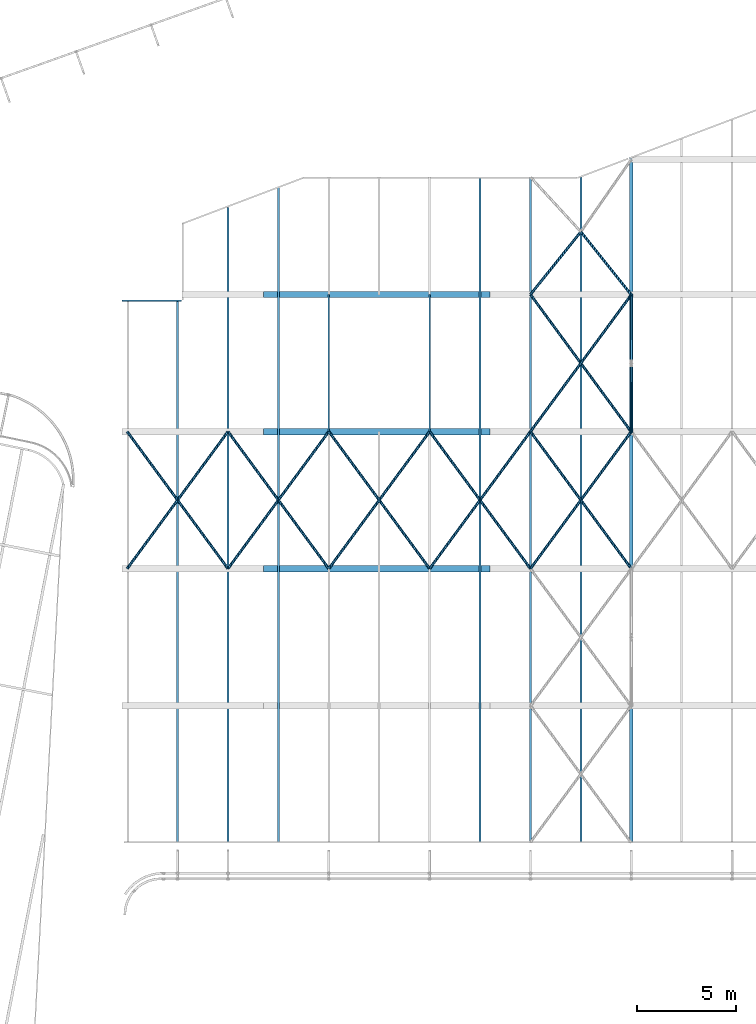
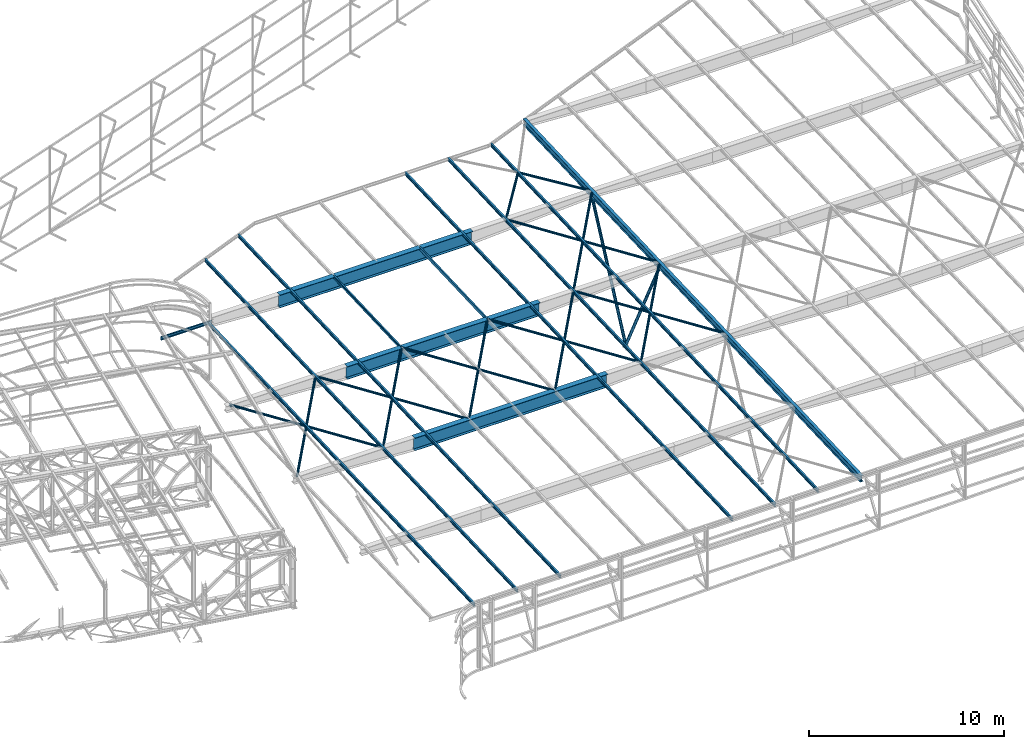
# One storey, part 114 of 215: 27 beams, 2 members, 29 elements without a shape of their own.
"""IFC2X3 building model written with IfcOpenShell, lengths in millimetres."""

from ifc_helpers import new_model, si_unit, frame, origin_with_axes, origin_2d_with_axis, place, context, subcontext, project, spatial, hollow_circle, i_section, u_section, extrude, clip, halfspace, material, type_object, element, aggregate, save


model = new_model("IFC2X3")

# Units and contexts
model_context = context("Model", 3, precision=1e-05, world=origin_with_axes())
body_context = subcontext(model_context, "Body", "Model", "MODEL_VIEW")
ifc_project = project(units=[si_unit("LENGTHUNIT", "METRE", prefix="MILLI"), si_unit("AREAUNIT", "SQUARE_METRE"), si_unit("VOLUMEUNIT", "CUBIC_METRE"), si_unit("MASSUNIT", "GRAM", prefix="KILO"), si_unit("TIMEUNIT", "SECOND"), si_unit("PLANEANGLEUNIT", "RADIAN"), si_unit("SOLIDANGLEUNIT", "STERADIAN"), si_unit("THERMODYNAMICTEMPERATUREUNIT", "DEGREE_CELSIUS"), si_unit("LUMINOUSINTENSITYUNIT", "LUMEN")], contexts=[model_context])

# Site, building, storey
site_placement = place(None, origin_with_axes())
site = spatial("IfcSite", under=ifc_project, at=site_placement, CompositionType="ELEMENT")
building_placement = place(site_placement, origin_with_axes())
building = spatial("IfcBuilding", under=site, at=building_placement, Name="Undefined", CompositionType="ELEMENT")
storey_placement = place(building_placement, origin_with_axes())
storey = spatial("IfcBuildingStorey", under=building, at=storey_placement, Name="Undefined", CompositionType="ELEMENT", Elevation=0.0)

# Assembly, beam
assembly_1_placement = place(storey_placement, origin_with_axes())
assembly_1 = element("IfcElementAssembly", 1, at=assembly_1_placement, inside=storey, Name="Steel Assembly", AssemblyPlace="NOTDEFINED", PredefinedType="RIGID_FRAME")
ifc_material_1 = material(Name="STEEL/S275JR")
beam_type_1 = type_object("IfcBeamType", Name="UPE200", PredefinedType="NOTDEFINED")
beam_1_placement = place(assembly_1_placement, frame((103874.07781238, 62264.9270571138, 3922.84069857706), z_axis=(0.0, 0.0, 1.0), x_axis=(1.0, 0.0, 0.0)))
beam_1 = element("IfcBeam", 2, at=beam_1_placement, type_object=beam_type_1, material=ifc_material_1, ObjectType="UPE200", context=body_context, shape_type="SweptSolid", body=[
    extrude(u_section(Depth=200.0, FlangeWidth=80.0, WebThickness=6.0, FlangeThickness=11.0, FilletRadius=13.0, at=origin_2d_with_axis()), frame((2999.96948241417, 7.27595761418343e-12, -1.5881706202264e-19), z_axis=(-1.0, 0.0, 0.0), x_axis=(-6.93889390390723e-18, -1.0, -3.46944695195361e-18)), (0.0, 0.0, 1.0), 3000.0),
])
aggregate(assembly_1, [beam_1])

assembly_2_placement = place(storey_placement, origin_with_axes())
assembly_2 = element("IfcElementAssembly", 3, at=assembly_2_placement, inside=storey, Name="Steel Assembly", AssemblyPlace="NOTDEFINED", PredefinedType="RIGID_FRAME")
beam_2_placement = place(assembly_2_placement, frame((114285.009686581, 55679.2143666818, 3657.96601082623), z_axis=(0.0, 0.0399624260079826, -0.999201183199638), x_axis=(0.0, 0.999201183199638, 0.0399624260079844)))
beam_2 = element("IfcBeam", 4, at=beam_2_placement, type_object=beam_type_1, material=ifc_material_1, ObjectType="UPE200", context=body_context, shape_type="SweptSolid", body=[
    extrude(u_section(Depth=200.0, FlangeWidth=80.0, WebThickness=6.0, FlangeThickness=11.0, FilletRadius=13.0, at=origin_2d_with_axis()), frame((6917.37608118615, 0.0, 0.0), z_axis=(-1.0, 0.0, 0.0), x_axis=(-6.93889390390723e-18, -1.0, -3.46944695195361e-18)), (0.0, 0.0, 1.0), 6917.4),
])
aggregate(assembly_2, [beam_2])

assembly_3_placement = place(storey_placement, origin_with_axes())
assembly_3 = element("IfcElementAssembly", 5, at=assembly_3_placement, inside=storey, Name="Steel Assembly", AssemblyPlace="NOTDEFINED", PredefinedType="RIGID_FRAME")
beam_3_placement = place(assembly_3_placement, frame((119365.009192493, 55679.2143655956, 3657.96601154322), z_axis=(0.0, -0.0399624260079826, 0.999201183199638), x_axis=(0.0, 0.999201183199638, 0.0399624260079844)))
beam_3 = element("IfcBeam", 6, at=beam_3_placement, type_object=beam_type_1, material=ifc_material_1, ObjectType="UPE200", context=body_context, shape_type="SweptSolid", body=[
    extrude(u_section(Depth=200.0, FlangeWidth=80.0, WebThickness=6.0, FlangeThickness=11.0, FilletRadius=13.0, at=origin_2d_with_axis()), frame((6917.37608118615, 0.0, 0.0), z_axis=(-1.0, 0.0, 0.0), x_axis=(-6.93889390390723e-18, -1.0, -3.46944695195361e-18)), (0.0, 0.0, 1.0), 6917.4),
])
aggregate(assembly_3, [beam_3])

assembly_4_placement = place(storey_placement, origin_with_axes())
assembly_4 = element("IfcElementAssembly", 7, at=assembly_4_placement, inside=storey, Name="Steel Assembly", AssemblyPlace="NOTDEFINED", PredefinedType="RIGID_FRAME")
beam_type_2 = type_object("IfcBeamType", Name="IPE200", PredefinedType="NOTDEFINED")
beam_4_placement = place(assembly_4_placement, frame((126985.008449978, 34986.5208587922, 2830.37468372193), z_axis=(0.0, -0.0399624260079826, 0.999201183199638), x_axis=(0.0, 0.999201183199638, 0.0399624260079844)))
beam_4 = element("IfcBeam", 8, at=beam_4_placement, type_object=beam_type_2, material=ifc_material_1, ObjectType="IPE200", context=body_context, shape_type="SweptSolid", body=[
    extrude(i_section(OverallWidth=100.0, OverallDepth=200.0, WebThickness=5.599999905, FlangeThickness=8.5, FilletRadius=12.0, at=origin_2d_with_axis()), frame((33540.0009155556, 0.0, -2.32730507889992e-13), z_axis=(-1.0, 0.0, 0.0), x_axis=(-6.93889390390723e-18, -1.0, -3.46944695195361e-18)), (0.0, 0.0, 1.0), 33540.0),
])
aggregate(assembly_4, [beam_4])

assembly_5_placement = place(storey_placement, origin_with_axes())
assembly_5 = element("IfcElementAssembly", 9, at=assembly_5_placement, inside=storey, Name="Steel Assembly", AssemblyPlace="NOTDEFINED", PredefinedType="RIGID_FRAME")
beam_5_placement = place(assembly_5_placement, frame((124445.008696082, 34986.5208587917, 2830.37468373617), z_axis=(0.0, -0.0399624260079826, 0.999201183199638), x_axis=(0.0, 0.999201183199638, 0.0399624260079844)))
beam_5 = element("IfcBeam", 10, at=beam_5_placement, type_object=beam_type_2, material=ifc_material_1, ObjectType="IPE200", context=body_context, shape_type="SweptSolid", body=[
    extrude(i_section(OverallWidth=100.0, OverallDepth=200.0, WebThickness=5.599999905, FlangeThickness=8.5, FilletRadius=12.0, at=origin_2d_with_axis()), frame((33540.0009155556, 0.0, -2.32730507889992e-13), z_axis=(-1.0, 0.0, 0.0), x_axis=(-6.93889390390723e-18, -1.0, -3.46944695195361e-18)), (0.0, 0.0, 1.0), 33540.0),
])
aggregate(assembly_5, [beam_5])

assembly_6_placement = place(storey_placement, origin_with_axes())
assembly_6 = element("IfcElementAssembly", 11, at=assembly_6_placement, inside=storey, Name="Steel Assembly", AssemblyPlace="NOTDEFINED", PredefinedType="RIGID_FRAME")
beam_6_placement = place(assembly_6_placement, frame((121905.008942186, 34986.5208587911, 2830.37468375042), z_axis=(0.0, -0.0399624260079826, 0.999201183199638), x_axis=(0.0, 0.999201183199638, 0.0399624260079844)))
beam_6 = element("IfcBeam", 12, at=beam_6_placement, type_object=beam_type_2, material=ifc_material_1, ObjectType="IPE200", context=body_context, shape_type="SweptSolid", body=[
    extrude(i_section(OverallWidth=100.0, OverallDepth=200.0, WebThickness=5.599999905, FlangeThickness=8.5, FilletRadius=12.0, at=origin_2d_with_axis()), frame((33540.0009155556, 0.0, -2.32730507889992e-13), z_axis=(-1.0, 0.0, 0.0), x_axis=(-6.93889390390723e-18, -1.0, -3.46944695195361e-18)), (0.0, 0.0, 1.0), 33540.0),
])
aggregate(assembly_6, [beam_6])

assembly_7_placement = place(storey_placement, origin_with_axes())
assembly_7 = element("IfcElementAssembly", 13, at=assembly_7_placement, inside=storey, Name="Steel Assembly", AssemblyPlace="NOTDEFINED", PredefinedType="RIGID_FRAME")
beam_7_placement = place(assembly_7_placement, frame((111745.009926601, 34986.520858789, 2830.37468380739), z_axis=(0.0, -0.0399624260079826, 0.999201183199638), x_axis=(0.0, 0.999201183199638, 0.0399624260079844)))
beam_7 = element("IfcBeam", 14, at=beam_7_placement, type_object=beam_type_2, material=ifc_material_1, ObjectType="IPE200", context=body_context, shape_type="SweptSolid", body=[
    extrude(i_section(OverallWidth=100.0, OverallDepth=200.0, WebThickness=5.599999905, FlangeThickness=8.5, FilletRadius=12.0, at=origin_2d_with_axis()), frame((33016.5951469897, 1.45519152283669e-11, 2.2909865079322e-13), z_axis=(-1.0, 0.0, 0.0), x_axis=(-6.93889390390723e-18, -1.0, -3.46944695195361e-18)), (0.0, 0.0, 1.0), 33016.6),
])
aggregate(assembly_7, [beam_7])

assembly_8_placement = place(storey_placement, origin_with_axes())
assembly_8 = element("IfcElementAssembly", 15, at=assembly_8_placement, inside=storey, Name="Steel Assembly", AssemblyPlace="NOTDEFINED", PredefinedType="RIGID_FRAME")
beam_8_placement = place(assembly_8_placement, frame((109205.010172706, 34986.5208587882, 2830.37468382162), z_axis=(0.0, -0.0399624260079826, 0.999201183199638), x_axis=(0.0, 0.999201183199638, 0.0399624260079844)))
beam_8 = element("IfcBeam", 16, at=beam_8_placement, type_object=beam_type_2, material=ifc_material_1, ObjectType="IPE200", context=body_context, shape_type="SweptSolid", body=[
    extrude(i_section(OverallWidth=100.0, OverallDepth=200.0, WebThickness=5.599999905, FlangeThickness=8.5, FilletRadius=12.0, at=origin_2d_with_axis()), frame((32004.8176002032, 0.0, 0.0), z_axis=(-1.0, 0.0, 0.0), x_axis=(-6.93889390390723e-18, -1.0, -3.46944695195361e-18)), (0.0, 0.0, 1.0), 32004.8),
])
aggregate(assembly_8, [beam_8])

assembly_9_placement = place(storey_placement, origin_with_axes())
assembly_9 = element("IfcElementAssembly", 17, at=assembly_9_placement, inside=storey, Name="Steel Assembly", AssemblyPlace="NOTDEFINED", PredefinedType="RIGID_FRAME")
beam_9_placement = place(assembly_9_placement, frame((106665.01041881, 34986.5208587875, 2830.37468383587), z_axis=(0.0, -0.0399624260079826, 0.999201183199638), x_axis=(0.0, 0.999201183199638, 0.0399624260079844)))
beam_9 = element("IfcBeam", 18, at=beam_9_placement, type_object=beam_type_2, material=ifc_material_1, ObjectType="IPE200", context=body_context, shape_type="SweptSolid", body=[
    extrude(i_section(OverallWidth=100.0, OverallDepth=200.0, WebThickness=5.599999905, FlangeThickness=8.5, FilletRadius=12.0, at=origin_2d_with_axis()), frame((27339.3286040039, 0.0, 0.0), z_axis=(-1.0, 0.0, 0.0), x_axis=(-6.93889390390723e-18, -1.0, -3.46944695195361e-18)), (0.0, 0.0, 1.0), 27339.3),
])
aggregate(assembly_9, [beam_9])

assembly_10_placement = place(storey_placement, origin_with_axes())
assembly_10 = element("IfcElementAssembly", 19, at=assembly_10_placement, inside=storey, Name="Steel Assembly", AssemblyPlace="NOTDEFINED", PredefinedType="RIGID_FRAME")
ifc_material_2 = material(Name="STEEL/S235JR")
beam_type_3 = type_object("IfcBeamType", PredefinedType="NOTDEFINED")
beam_10_placement = place(assembly_10_placement, frame((109205.01032491, 55677.9851455817, 3688.04649082879), z_axis=(-2.1980000026525e-06, -0.0399625230126959, 0.999201179317573), x_axis=(-0.592192299082924, -0.805152939112744, -0.0322028810045093)))
beam_10 = element("IfcBeam", 20, at=beam_10_placement, type_object=beam_type_3, material=ifc_material_2, context=body_context, shape_type="SweptSolid", body=[
    extrude(hollow_circle(Radius=69.84999845, WallThickness=8.0, at=origin_2d_with_axis()), frame((8578.29376438585, 1.40580531169083e-11, 5.95238703076223e-14), z_axis=(-1.0, 0.0, 0.0), x_axis=(-6.93889390390723e-18, -1.0, -3.46944695195361e-18)), (0.0, 0.0, 1.0), 8578.3),
])
aggregate(assembly_10, [beam_10])

assembly_11_placement = place(storey_placement, origin_with_axes())
assembly_11 = element("IfcElementAssembly", 21, at=assembly_11_placement, inside=storey, Name="Steel Assembly", AssemblyPlace="NOTDEFINED", PredefinedType="RIGID_FRAME")
beam_11_placement = place(assembly_11_placement, frame((109205.010325098, 48771.1462654083, 3411.81179199568), z_axis=(-2.1980000026525e-06, -0.0399625230126959, 0.999201179317573), x_axis=(-0.592192299209504, 0.805153042284843, 0.0322002990113917)))
beam_11 = element("IfcBeam", 22, at=beam_11_placement, type_object=beam_type_3, material=ifc_material_2, context=body_context, shape_type="SweptSolid", body=[
    extrude(hollow_circle(Radius=69.84999845, WallThickness=8.0, at=origin_2d_with_axis()), frame((8578.29376438585, 1.40580531169083e-11, 5.95238703076223e-14), z_axis=(-1.0, 0.0, 0.0), x_axis=(-6.93889390390723e-18, -1.0, -3.46944695195361e-18)), (0.0, 0.0, 1.0), 8578.3),
])
aggregate(assembly_11, [beam_11])

assembly_12_placement = place(storey_placement, origin_with_axes())
assembly_12 = element("IfcElementAssembly", 23, at=assembly_12_placement, inside=storey, Name="Steel Assembly", AssemblyPlace="NOTDEFINED", PredefinedType="RIGID_FRAME")
beam_12_placement = place(assembly_12_placement, frame((114285.009832587, 55677.9847029314, 3688.05756124109), z_axis=(-2.1980000026525e-06, -0.0399625230126959, 0.999201179317573), x_axis=(-0.592192299082924, -0.805152939112744, -0.0322028810045093)))
beam_12 = element("IfcBeam", 24, at=beam_12_placement, type_object=beam_type_3, material=ifc_material_2, context=body_context, shape_type="SweptSolid", body=[
    extrude(hollow_circle(Radius=69.84999845, WallThickness=8.0, at=origin_2d_with_axis()), frame((8578.29376438585, 1.40580531169083e-11, 5.95238703076223e-14), z_axis=(-1.0, 0.0, 0.0), x_axis=(-6.93889390390723e-18, -1.0, -3.46944695195361e-18)), (0.0, 0.0, 1.0), 8578.3),
])
aggregate(assembly_12, [beam_12])

assembly_13_placement = place(storey_placement, origin_with_axes())
assembly_13 = element("IfcElementAssembly", 25, at=assembly_13_placement, inside=storey, Name="Steel Assembly", AssemblyPlace="NOTDEFINED", PredefinedType="RIGID_FRAME")
beam_13_placement = place(assembly_13_placement, frame((114285.009833476, 48771.1458231269, 3411.82286240553), z_axis=(-2.1980000026525e-06, -0.0399625230126959, 0.999201179317573), x_axis=(-0.592192299209504, 0.805153042284843, 0.0322002990113917)))
beam_13 = element("IfcBeam", 26, at=beam_13_placement, type_object=beam_type_3, material=ifc_material_2, context=body_context, shape_type="SweptSolid", body=[
    extrude(hollow_circle(Radius=69.84999845, WallThickness=8.0, at=origin_2d_with_axis()), frame((8578.29376438585, 1.40580531169083e-11, 5.95238703076223e-14), z_axis=(-1.0, 0.0, 0.0), x_axis=(-6.93889390390723e-18, -1.0, -3.46944695195361e-18)), (0.0, 0.0, 1.0), 8578.3),
])
aggregate(assembly_13, [beam_13])

assembly_14_placement = place(storey_placement, origin_with_axes())
assembly_14 = element("IfcElementAssembly", 27, at=assembly_14_placement, inside=storey, Name="Steel Assembly", AssemblyPlace="NOTDEFINED", PredefinedType="RIGID_FRAME")
beam_14_placement = place(assembly_14_placement, frame((119365.009339852, 55677.9842595072, 3688.068631527), z_axis=(-2.1980000026525e-06, -0.0399625230126959, 0.999201179317573), x_axis=(-0.592192299082924, -0.805152939112744, -0.0322028810045093)))
beam_14 = element("IfcBeam", 28, at=beam_14_placement, type_object=beam_type_3, material=ifc_material_2, context=body_context, shape_type="SweptSolid", body=[
    extrude(hollow_circle(Radius=69.84999845, WallThickness=8.0, at=origin_2d_with_axis()), frame((8578.29376438585, 1.40580531169083e-11, 5.95238703076223e-14), z_axis=(-1.0, 0.0, 0.0), x_axis=(-6.93889390390723e-18, -1.0, -3.46944695195361e-18)), (0.0, 0.0, 1.0), 8578.3),
])
aggregate(assembly_14, [beam_14])

assembly_15_placement = place(storey_placement, origin_with_axes())
assembly_15 = element("IfcElementAssembly", 29, at=assembly_15_placement, inside=storey, Name="Steel Assembly", AssemblyPlace="NOTDEFINED", PredefinedType="RIGID_FRAME")
beam_15_placement = place(assembly_15_placement, frame((119365.009342043, 48771.1453798434, 3411.83393277177), z_axis=(-2.1980000026525e-06, -0.0399625230126959, 0.999201179317573), x_axis=(-0.592192299209504, 0.805153042284843, 0.0322002990113917)))
beam_15 = element("IfcBeam", 30, at=beam_15_placement, type_object=beam_type_3, material=ifc_material_2, context=body_context, shape_type="SweptSolid", body=[
    extrude(hollow_circle(Radius=69.84999845, WallThickness=8.0, at=origin_2d_with_axis()), frame((8578.29376438585, 1.40580531169083e-11, 5.95238703076223e-14), z_axis=(-1.0, 0.0, 0.0), x_axis=(-6.93889390390723e-18, -1.0, -3.46944695195361e-18)), (0.0, 0.0, 1.0), 8578.3),
])
aggregate(assembly_15, [beam_15])

assembly_16_placement = place(storey_placement, origin_with_axes())
assembly_16 = element("IfcElementAssembly", 31, at=assembly_16_placement, inside=storey, Name="Steel Assembly", AssemblyPlace="NOTDEFINED", PredefinedType="RIGID_FRAME")
beam_16_placement = place(assembly_16_placement, frame((124445.008850213, 55677.983818404, 3688.0797020238), z_axis=(-2.1980000026525e-06, -0.0399625230126959, 0.999201179317573), x_axis=(-0.592192299082924, -0.805152939112744, -0.0322028810045093)))
beam_16 = element("IfcBeam", 32, at=beam_16_placement, type_object=beam_type_3, material=ifc_material_2, context=body_context, shape_type="SweptSolid", body=[
    extrude(hollow_circle(Radius=69.84999845, WallThickness=8.0, at=origin_2d_with_axis()), frame((8578.29376438585, 1.40580531169083e-11, 5.95238703076223e-14), z_axis=(-1.0, 0.0, 0.0), x_axis=(-6.93889390390723e-18, -1.0, -3.46944695195361e-18)), (0.0, 0.0, 1.0), 8578.3),
])
aggregate(assembly_16, [beam_16])

assembly_17_placement = place(storey_placement, origin_with_axes())
assembly_17 = element("IfcElementAssembly", 33, at=assembly_17_placement, inside=storey, Name="Steel Assembly", AssemblyPlace="NOTDEFINED", PredefinedType="RIGID_FRAME")
beam_17_placement = place(assembly_17_placement, frame((124445.008847071, 48771.1449382416, 3411.84500316869), z_axis=(-2.1980000026525e-06, -0.0399625230126959, 0.999201179317573), x_axis=(-0.592192299209504, 0.805153042284843, 0.0322002990113917)))
beam_17 = element("IfcBeam", 34, at=beam_17_placement, type_object=beam_type_3, material=ifc_material_2, context=body_context, shape_type="SweptSolid", body=[
    extrude(hollow_circle(Radius=69.84999845, WallThickness=8.0, at=origin_2d_with_axis()), frame((8578.29376438585, 1.40580531169083e-11, 5.95238703076223e-14), z_axis=(-1.0, 0.0, 0.0), x_axis=(-6.93889390390723e-18, -1.0, -3.46944695195361e-18)), (0.0, 0.0, 1.0), 8578.3),
])
aggregate(assembly_17, [beam_17])

assembly_18_placement = place(storey_placement, origin_with_axes())
assembly_18 = element("IfcElementAssembly", 35, at=assembly_18_placement, inside=storey, Name="Steel Assembly", AssemblyPlace="NOTDEFINED", PredefinedType="RIGID_FRAME")
beam_18_placement = place(assembly_18_placement, frame((129525.007395596, 62569.0870364156, 3963.69615075662), z_axis=(-9.29999994281054e-07, -0.0399614169821636, 0.999201223554051), x_axis=(-0.624244095091181, 0.780605357114021, 0.03121836300456)))
beam_18 = element("IfcBeam", 36, at=beam_18_placement, type_object=beam_type_3, material=ifc_material_2, context=body_context, shape_type="SweptSolid", body=[
    extrude(hollow_circle(Radius=69.84999845, WallThickness=8.0, at=origin_2d_with_axis()), frame((4068.91935908798, -3.5909864039563e-13, 2.41490575311365e-13), z_axis=(-1.0, 0.0, 0.0), x_axis=(-6.93889390390723e-18, -1.0, -3.46944695195361e-18)), (0.0, 0.0, 1.0), 4068.9),
])
aggregate(assembly_18, [beam_18])

assembly_19_placement = place(storey_placement, origin_with_axes())
assembly_19 = element("IfcElementAssembly", 37, at=assembly_19_placement, inside=storey, Name="Steel Assembly", AssemblyPlace="NOTDEFINED", PredefinedType="RIGID_FRAME")
beam_19_placement = place(assembly_19_placement, frame((124445.008846382, 62584.8226868051, 3964.31440003806), z_axis=(-2.1980000026525e-06, -0.0399625230126959, 0.999201179317573), x_axis=(0.62613554378389, 0.779091330731097, 0.031160538989245)))
beam_19 = element("IfcBeam", 38, at=beam_19_placement, type_object=beam_type_3, material=ifc_material_2, context=body_context, shape_type="SweptSolid", body=[
    extrude(hollow_circle(Radius=69.84999845, WallThickness=8.0, at=origin_2d_with_axis()), frame((4056.62923766624, 2.03197127939003e-13, 7.1026954621735e-13), z_axis=(-1.0, 0.0, 0.0), x_axis=(-6.93889390390723e-18, -1.0, -3.46944695195361e-18)), (0.0, 0.0, 1.0), 4056.6),
])
aggregate(assembly_19, [beam_19])

assembly_20_placement = place(storey_placement, origin_with_axes())
assembly_20 = element("IfcElementAssembly", 39, at=assembly_20_placement, inside=storey, Name="Steel Assembly", AssemblyPlace="NOTDEFINED", PredefinedType="RIGID_FRAME")
beam_20_placement = place(assembly_20_placement, frame((129525.007485317, 55662.2504069331, 3687.46154225033), z_axis=(-2.1980000026525e-06, -0.0399625230126959, 0.999201179317573), x_axis=(-0.591317297898593, 0.805794849861813, 0.0322259699944735)))
beam_20 = element("IfcBeam", 40, at=beam_20_placement, type_object=beam_type_3, material=ifc_material_2, context=body_context, shape_type="SweptSolid", body=[
    extrude(hollow_circle(Radius=69.84999845, WallThickness=8.0, at=origin_2d_with_axis()), frame((8590.98601613036, 3.26934236157088e-13, 2.86985615939111e-13), z_axis=(-1.0, 0.0, 0.0), x_axis=(-6.93889390390723e-18, -1.0, -3.46944695195361e-18)), (0.0, 0.0, 1.0), 8591.0),
])
aggregate(assembly_20, [beam_20])

assembly_21_placement = place(storey_placement, origin_with_axes())
assembly_21 = element("IfcElementAssembly", 41, at=assembly_21_placement, inside=storey, Name="Steel Assembly", AssemblyPlace="NOTDEFINED", PredefinedType="RIGID_FRAME")
beam_21_placement = place(assembly_21_placement, frame((124445.008850213, 55677.983818404, 3688.0797020238), z_axis=(-2.1980000026525e-06, -0.0399625230126959, 0.999201179317573), x_axis=(0.593069181044462, 0.804508285060313, 0.0321771000024123)))
beam_21 = element("IfcBeam", 42, at=beam_21_placement, type_object=beam_type_3, material=ifc_material_2, context=body_context, shape_type="SweptSolid", body=[
    extrude(hollow_circle(Radius=69.84999845, WallThickness=8.0, at=origin_2d_with_axis()), frame((8565.60886410277, -1.57137003809309e-11, 0.0), z_axis=(-1.0, 0.0, 0.0), x_axis=(-6.93889390390723e-18, -1.0, -3.46944695195361e-18)), (0.0, 0.0, 1.0), 8565.6),
])
aggregate(assembly_21, [beam_21])

assembly_22_placement = place(storey_placement, origin_with_axes())
assembly_22 = element("IfcElementAssembly", 43, at=assembly_22_placement, inside=storey, Name="Steel Assembly", AssemblyPlace="NOTDEFINED", PredefinedType="RIGID_FRAME")
beam_22_placement = place(assembly_22_placement, frame((129525.008343412, 48771.1444955333, 3411.85607358075), z_axis=(-2.1980000026525e-06, -0.0399625230126959, 0.999201179317573), x_axis=(-0.592192299209504, 0.805153042284843, 0.0322002990113917)))
beam_22 = element("IfcBeam", 44, at=beam_22_placement, type_object=beam_type_3, material=ifc_material_2, context=body_context, shape_type="SweptSolid", body=[
    extrude(hollow_circle(Radius=69.84999845, WallThickness=8.0, at=origin_2d_with_axis()), frame((8578.29376438585, 1.40580531169083e-11, 5.95238703076223e-14), z_axis=(-1.0, 0.0, 0.0), x_axis=(-6.93889390390723e-18, -1.0, -3.46944695195361e-18)), (0.0, 0.0, 1.0), 8578.3),
])
aggregate(assembly_22, [beam_22])

assembly_23_placement = place(storey_placement, origin_with_axes())
assembly_23 = element("IfcElementAssembly", 45, at=assembly_23_placement, inside=storey, Name="Steel Assembly", AssemblyPlace="NOTDEFINED", PredefinedType="RIGID_FRAME")
beam_23_placement = place(assembly_23_placement, frame((124445.008847071, 48771.1449382416, 3411.84500316869), z_axis=(-2.1980000026525e-06, -0.0399625230126959, 0.999201179317573), x_axis=(0.592192300877416, 0.805152937833333, 0.032202879993334)))
beam_23 = element("IfcBeam", 46, at=beam_23_placement, type_object=beam_type_3, material=ifc_material_2, context=body_context, shape_type="SweptSolid", body=[
    extrude(hollow_circle(Radius=69.84999845, WallThickness=8.0, at=origin_2d_with_axis()), frame((8578.29376438585, 1.40580531169083e-11, 5.95238703076223e-14), z_axis=(-1.0, 0.0, 0.0), x_axis=(-6.93889390390723e-18, -1.0, -3.46944695195361e-18)), (0.0, 0.0, 1.0), 8578.3),
])
aggregate(assembly_23, [beam_23])

assembly_24_placement = place(storey_placement, origin_with_axes())
assembly_24 = element("IfcElementAssembly", 47, at=assembly_24_placement, inside=storey, Name="Steel Assembly", AssemblyPlace="NOTDEFINED", PredefinedType="RIGID_FRAME")
ifc_material_3 = material(Name="STEEL/S355JR")
beam_type_4 = type_object("IfcBeamType", PredefinedType="NOTDEFINED")
beam_24_placement = place(assembly_24_placement, frame((110996.242112218, 62582.2879153396, 3627.692787142), z_axis=(0.0, 0.0, -1.0), x_axis=(1.0, 0.0, 0.0)))
beam_24 = element("IfcBeam", 48, at=beam_24_placement, type_object=beam_type_4, material=ifc_material_3, Name="POUTRE", context=body_context, shape_type="SweptSolid", body=[
    extrude(i_section(OverallWidth=320.0, OverallDepth=800.0, WebThickness=6.0, FlangeThickness=20.0, FilletRadius=4.2, at=origin_2d_with_axis()), frame((11406.6037240309, 0.0, 0.0), z_axis=(-1.0, 0.0, 0.0), x_axis=(-6.93889390390723e-18, -1.0, -3.46944695195361e-18)), (0.0, 0.0, 1.0), 11406.6),
])
aggregate(assembly_24, [beam_24])

assembly_25_placement = place(storey_placement, origin_with_axes())
assembly_25 = element("IfcElementAssembly", 49, at=assembly_25_placement, inside=storey, Name="Steel Assembly", AssemblyPlace="NOTDEFINED", PredefinedType="RIGID_FRAME")
beam_25_placement = place(assembly_25_placement, frame((110996.242112218, 55675.4505269513, 3351.42084494825), z_axis=(0.0, 0.0, -1.0), x_axis=(1.0, 0.0, 0.0)))
beam_25 = element("IfcBeam", 50, at=beam_25_placement, type_object=beam_type_4, material=ifc_material_3, Name="POUTRE", context=body_context, shape_type="SweptSolid", body=[
    extrude(i_section(OverallWidth=320.0, OverallDepth=800.0, WebThickness=6.0, FlangeThickness=20.0, FilletRadius=4.2, at=origin_2d_with_axis()), frame((11406.6037240309, 0.0, 0.0), z_axis=(-1.0, 0.0, 0.0), x_axis=(-6.93889390390723e-18, -1.0, -3.46944695195361e-18)), (0.0, 0.0, 1.0), 11406.6),
])
aggregate(assembly_25, [beam_25])

assembly_26_placement = place(storey_placement, origin_with_axes())
assembly_26 = element("IfcElementAssembly", 51, at=assembly_26_placement, inside=storey, Name="Steel Assembly", AssemblyPlace="NOTDEFINED", PredefinedType="RIGID_FRAME")
beam_26_placement = place(assembly_26_placement, frame((110996.242112218, 48768.6131385631, 3075.14891283815), z_axis=(0.0, 0.0, -1.0), x_axis=(1.0, 0.0, 0.0)))
beam_26 = element("IfcBeam", 52, at=beam_26_placement, type_object=beam_type_4, material=ifc_material_3, Name="POUTRE", context=body_context, shape_type="SweptSolid", body=[
    extrude(i_section(OverallWidth=320.0, OverallDepth=800.0, WebThickness=6.0, FlangeThickness=20.0, FilletRadius=4.2, at=origin_2d_with_axis()), frame((11406.6037240309, 0.0, 0.0), z_axis=(-1.0, 0.0, 0.0), x_axis=(-6.93889390390723e-18, -1.0, -3.46944695195361e-18)), (0.0, 0.0, 1.0), 11406.6),
])
aggregate(assembly_26, [beam_26])

assembly_27_placement = place(storey_placement, origin_with_axes())
assembly_27 = element("IfcElementAssembly", 53, at=assembly_27_placement, inside=storey, Name="Steel Assembly", AssemblyPlace="NOTDEFINED", PredefinedType="RIGID_FRAME")
beam_type_5 = type_object("IfcBeamType", Name="IPE400", PredefinedType="NOTDEFINED")
beam_27_placement = place(assembly_27_placement, frame((129525.008205592, 34962.9337155165, 2729.16485538743), z_axis=(0.0, 0.0399678139878515, -0.999200967696205), x_axis=(0.0, 0.999200967696205, 0.0399678139878483)))
beam_27 = element("IfcBeam", 54, at=beam_27_placement, type_object=beam_type_5, material=ifc_material_1, Name="TRAVERSE", ObjectType="IPE400", context=body_context, shape_type="SweptSolid", body=[
    extrude(i_section(OverallWidth=180.0, OverallDepth=400.0, WebThickness=8.600000381, FlangeThickness=13.5, FilletRadius=21.0, at=origin_2d_with_axis()), frame((34561.5078013691, 0.0, 2.39818635792762e-13), z_axis=(-1.0, 0.0, 0.0), x_axis=(-6.93889390390723e-18, -1.0, -3.46944695195361e-18)), (0.0, 0.0, 1.0), 34561.5),
])
aggregate(assembly_27, [beam_27])

# Assembly, member
assembly_28_placement = place(storey_placement, origin_with_axes())
assembly_28 = element("IfcElementAssembly", 55, at=assembly_28_placement, inside=storey, Name="Steel Assembly", AssemblyPlace="NOTDEFINED", PredefinedType="RIGID_FRAME")
member_type = type_object("IfcMemberType", PredefinedType="NOTDEFINED")
member_1_placement = place(assembly_28_placement, frame((129525.008205612, 62582.2821900387, 3633.77287754243), z_axis=(-1.0, 0.0, 0.0), x_axis=(0.0, -0.432426789007335, -0.901669048015294)))
member_1 = element("IfcMember", 56, at=member_1_placement, type_object=member_type, material=ifc_material_1, Name="POUTRE", context=body_context, shape_type="Clipping", body=[
    clip(clip(extrude(hollow_circle(Radius=84.15000155, WallThickness=10.0, at=origin_2d_with_axis()), frame((8053.57743232614, 0.0, 0.0), z_axis=(-1.0, 0.0, 0.0), x_axis=(-6.93889390390723e-18, -1.0, -3.46944695195361e-18)), (0.0, 0.0, 1.0), 8053.6), halfspace(frame((8029.72909482703, 84.1500015499987, 84.150001550006), z_axis=(0.901669048015295, -0.432426789007331, 0.0), x_axis=(0.0, 0.0, -1.0)), False)), halfspace(frame((7968.01405479704, 4.68739919137442, 2.03435774892569e-08), z_axis=(-0.432426789007244, -0.901669048015338, 0.0), x_axis=(0.0, 0.0, -1.0)), True)),
])
aggregate(assembly_28, [member_1])

assembly_29_placement = place(storey_placement, origin_with_axes())
assembly_29 = element("IfcElementAssembly", 57, at=assembly_29_placement, inside=storey, Name="Steel Assembly", AssemblyPlace="NOTDEFINED", PredefinedType="RIGID_FRAME")
member_2_placement = place(assembly_29_placement, frame((129525.008205612, 55675.4469749916, 3357.50093535257), z_axis=(-1.0, 0.0, 0.0), x_axis=(0.0, 0.446001520745479, -0.895032202489229)))
member_2 = element("IfcMember", 58, at=member_2_placement, type_object=member_type, material=ifc_material_1, Name="POUTRE", context=body_context, shape_type="Clipping", body=[
    clip(clip(extrude(hollow_circle(Radius=84.15000155, WallThickness=10.0, at=origin_2d_with_axis()), frame((7805.65680665301, -7.27595761418343e-12, 0.0), z_axis=(-1.0, 0.0, 0.0), x_axis=(-6.93889390390723e-18, -1.0, -3.46944695195361e-18)), (0.0, 0.0, 1.0), 7805.7), halfspace(frame((7781.87482069301, -84.1500015499987, -84.150001550006), z_axis=(0.89503220248923, 0.446001520745477, 0.0), x_axis=(0.0, 0.0, 1.0)), False)), halfspace(frame((7714.85634834725, -6.91409324308916, 2.03435774892569e-08), z_axis=(0.446001520745543, -0.895032202489197, 0.0), x_axis=(0.0, 0.0, -1.0)), False)),
])
aggregate(assembly_29, [member_2])

save(model, "model.ifc")
